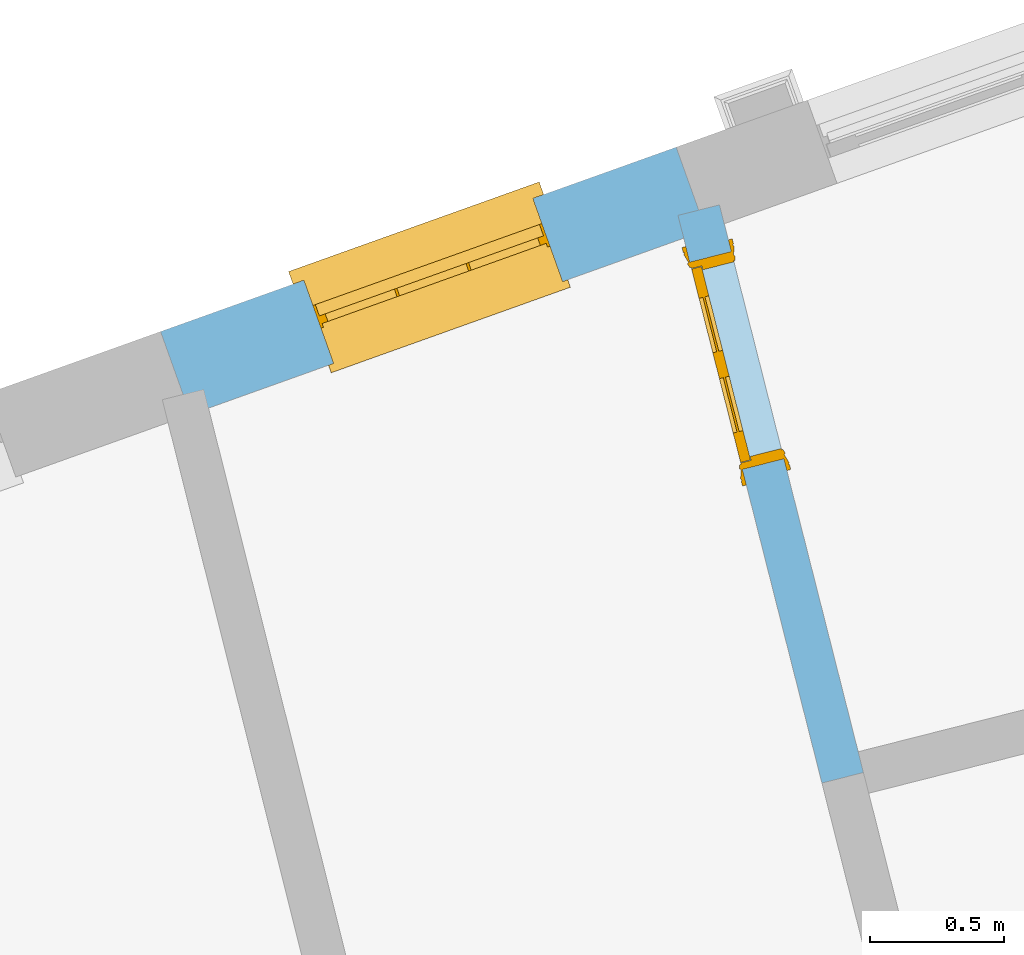
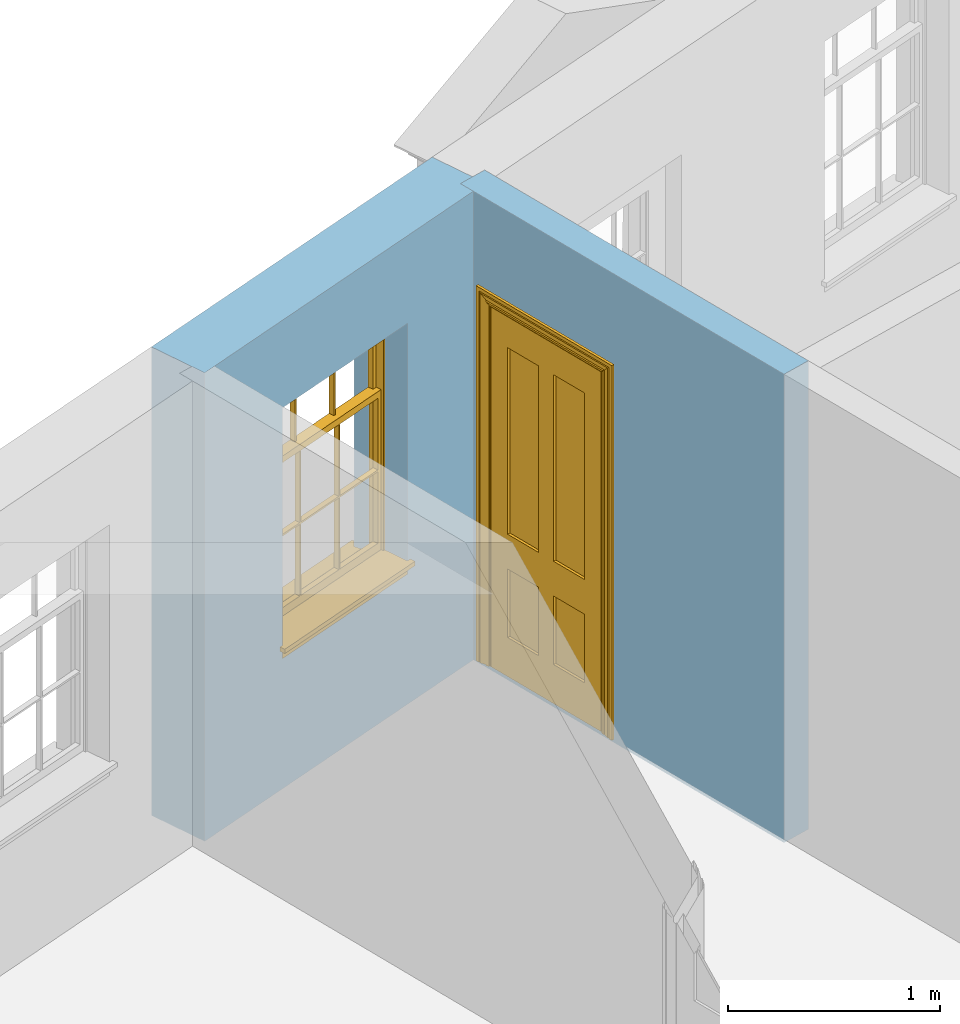
# One storey, part 10 of 15: 1 door, 1 window, 2 openings, plus 2 elements that do not belong to this part.
"""IFC2X3 building model written with IfcOpenShell, lengths in metres."""

from ifc_helpers import new_model, si_unit, frame, origin, place, context, subcontext, project, spatial, polyline, outline, extrude, faceted_brep, material, layer, layer_set, layer_usage, element, fill, save


model = new_model("IFC2X3")

# Units and contexts
model_context = context("Model", 3, world=origin())
body_context = subcontext(model_context, "Body", "Model", "MODEL_VIEW")
ifc_project = project(units=[si_unit("PLANEANGLEUNIT", "RADIAN"), si_unit("MASSUNIT", "GRAM", prefix="KILO"), si_unit("FORCEUNIT", "NEWTON", prefix="KILO"), si_unit("LENGTHUNIT", "METRE")], contexts=[model_context])

# Site, building, storey
site_placement = place(None, origin())
site = spatial("IfcSite", under=ifc_project, at=site_placement, CompositionType="ELEMENT")
building_placement = place(None, origin())
building = spatial("IfcBuilding", under=site, at=building_placement, Name="Building plot-13", CompositionType="ELEMENT")
storey_placement = place(None, frame((0.0, 0.0, 4.0)))
storey = spatial("IfcBuildingStorey", under=building, at=storey_placement, Name="Floor 0", CompositionType="ELEMENT", Elevation=4.0)

# Wall, opening, window
ifc_material_1 = material(Name="Masonry")
ifc_layer_1 = layer(ifc_material_1, 0.33, ventilated=False)
ifc_layer_set_1 = layer_set([ifc_layer_1], Name="My Wall")
ifc_layer_usage_1 = layer_usage(ifc_layer_set_1, "AXIS2", "NEGATIVE", 0.08)
wall_1_placement = place(storey_placement, origin())
wall_1 = element("IfcWallStandardCase", 1, at=wall_1_placement, inside=storey, material=ifc_layer_usage_1, Name="exterior", context=body_context, shape_type="SweptSolid", body=[
    extrude(outline(polyline([(72.090338058868, 49.7513205451126), (71.9792289491637, 50.0620531725284), (70.0510857180657, 49.3726042415572), (70.16219482777, 49.0618716141414), (72.090338058868, 49.7513205451126)])), origin(), (0.0, 0.0, 1.0), 2.7),
])
opening_1_placement = place(storey_placement, frame((0.0, 0.0, 0.75)))
opening_1 = element("IfcOpeningElement", 2, at=opening_1_placement, cuts=wall_1, Name="Opening", ObjectType="Opening", context=body_context, shape_type="SweptSolid", body=[
    extrude(outline(polyline([(71.4435917138395, 49.870524600726), (70.5867229533899, 49.5641328133596), (70.6978320630942, 49.2534001859438), (71.5547008235438, 49.5597919733102), (71.4435917138395, 49.870524600726)])), origin(), (0.0, 0.0, 1.0), 1.445),
])
window_placement = place(storey_placement, frame((71.5277652817973, 49.635121095108, 0.75), z_axis=(0.0, 0.0, 1.0), x_axis=(-0.856868760449586, -0.306391787366422, 0.0)))
window = element("IfcWindow", 3, at=window_placement, inside=storey, Name="circulation street window", OverallHeight=1.445, OverallWidth=0.91, context=body_context, shape_type="Brep", held_by="IfcProductRepresentation", body=[
    faceted_brep([(0.876875, -0.105, 0.999097), (0.876875, -0.105, 1.411875), (0.9, -0.105, 1.435), (0.033125, -0.105, 1.411875), (0.033125, -0.105, 0.999097), (0.01, -0.105, 1.435), (0.033125, -0.135, 1.411875), (0.01, -0.135, 1.435), (0.033125, -0.135, 0.999097), (0.876875, -0.135, 1.411875), (0.876875, -0.135, 0.999097), (0.9, -0.135, 1.435), (0.033125, -0.105, 0.960972), (0.01, -0.105, 0.960972), (0.033125, -0.105, 0.548195), (0.876875, -0.105, 0.960972), (0.876875, -0.105, 0.548195), (0.9, -0.105, 0.960972), (0.876875, -0.105, 0.538195), (0.876875, -0.105, 0.125417), (0.9, -0.105, 0.077167), (0.033125, -0.105, 0.125417), (0.033125, -0.105, 0.538195), (0.01, -0.105, 0.077167), (0.9, -0.135, 0.960972), (0.01, -0.135, 0.960972), (-0.0425, -0.25, 0.01), (-0.0425, -0.3, 0.001667), (0.0, -0.25, 0.01), (0.9525, -0.25, 0.01), (0.91, -0.25, 0.01), (0.9525, -0.3, 0.001667), (-0.02, 0.08, 0.077167), (0.0, 0.08, 0.077167), (-0.02, 0.11, 0.077167), (0.0, -0.06, 0.077167), (0.01, -0.06, 0.077167), (0.91, -0.06, 0.077167), (0.91, 0.08, 0.077167), (0.9, -0.06, 0.077167), (0.93, 0.08, 0.077167), (0.93, 0.11, 0.077167), (0.01, -0.105, 0.999097), (0.01, -0.075, 0.999097), (0.9, -0.105, 0.999097), (0.9, -0.075, 0.999097), (0.876875, -0.075, 0.125417), (0.876875, -0.075, 0.538195), (0.9, -0.075, 0.077167), (0.876875, -0.075, 0.548195), (0.876875, -0.075, 0.960972), (0.033125, -0.075, 0.125417), (0.01, -0.075, 0.077167), (0.033125, -0.075, 0.538195), (0.033125, -0.075, 0.960972), (0.033125, -0.075, 0.548195), (-0.02, 0.08, 0.052167), (-0.02, 0.11, 0.052167), (0.93, 0.11, 0.052167), (0.93, 0.08, 0.052167), (0.91, 0.08, 0.052167), (0.0, 0.08, 0.052167), (0.91, -0.15, 0.026667), (0.0, -0.15, 0.026667), (-0.0425, -0.3, -0.123333), (0.9525, -0.3, -0.123333), (-0.0425, -0.25, -0.123333), (0.9525, -0.25, -0.123333), (0.01, -0.06, 1.435), (0.9, -0.06, 1.435), (0.0, -0.06, 1.445), (0.91, -0.06, 1.445), (0.01, -0.15, 0.077167), (0.9, -0.15, 0.077167), (0.592292, -0.105, 0.125417), (0.592292, -0.075, 0.125417), (0.317708, -0.075, 0.125417), (0.317708, -0.105, 0.125417), (0.592292, -0.105, 0.548195), (0.317708, -0.105, 0.548195), (0.317708, -0.105, 0.538195), (0.592292, -0.105, 0.538195), (0.592292, -0.075, 0.548195), (0.317708, -0.075, 0.548195), (0.602292, -0.075, 0.548195), (0.602292, -0.105, 0.548195), (0.317708, -0.075, 0.538195), (0.307708, -0.075, 0.125417), (0.307708, -0.075, 0.538195), (0.602292, -0.075, 0.538195), (0.602292, -0.075, 0.125417), (0.592292, -0.075, 0.538195), (0.307708, -0.075, 0.548195), (0.317708, -0.075, 0.960972), (0.307708, -0.075, 0.960972), (0.602292, -0.075, 0.960972), (0.592292, -0.075, 0.960972), (0.307708, -0.105, 0.538195), (0.307708, -0.105, 0.125417), (0.307708, -0.105, 0.548195), (0.307708, -0.105, 0.960972), (0.592292, -0.105, 0.960972), (0.317708, -0.105, 0.960972), (0.602292, -0.105, 0.960972), (0.602292, -0.105, 0.538195), (0.602292, -0.105, 0.125417), (0.317708, -0.135, 1.411875), (0.307708, -0.135, 1.411875), (0.307708, -0.135, 0.999097), (0.317708, -0.135, 0.999097), (0.602292, -0.135, 1.411875), (0.592292, -0.135, 1.411875), (0.592292, -0.135, 0.999097), (0.602292, -0.135, 0.999097), (0.317708, -0.105, 0.999097), (0.307708, -0.105, 0.999097), (0.307708, -0.105, 1.411875), (0.317708, -0.105, 1.411875), (0.602292, -0.105, 0.999097), (0.592292, -0.105, 0.999097), (0.592292, -0.105, 1.411875), (0.602292, -0.105, 1.411875), (0.91, -0.15, 1.445), (0.9, -0.15, 1.435), (0.01, -0.15, 1.435), (0.0, -0.15, 1.445), (0.91, -0.25, 0.0), (0.0, -0.25, 0.0), (0.91, 0.08, 0.0), (0.0, 0.08, 0.0)], [[[0, 1, 2]], [[3, 4, 5]], [[6, 7, 8]], [[9, 10, 11]], [[12, 13, 14]], [[15, 16, 17]], [[18, 19, 20]], [[21, 22, 23]], [[24, 15, 17]], [[13, 12, 25]], [[26, 27, 28]], [[29, 30, 31]], [[32, 33, 34]], [[35, 36, 33]], [[37, 38, 39]], [[40, 41, 38]], [[42, 4, 43]], [[44, 45, 0]], [[46, 47, 48]], [[49, 50, 45]], [[51, 52, 53]], [[54, 55, 43]], [[38, 33, 36, 39]], [[41, 34, 33, 38]], [[56, 32, 34, 57]], [[57, 34, 41, 58]], [[58, 41, 40, 59]], [[57, 58, 60, 61]], [[52, 48, 39, 36]], [[62, 63, 28, 30]], [[27, 31, 30, 28]], [[27, 64, 65, 31]], [[66, 67, 65, 64]], [[2, 5, 68, 69]], [[68, 70, 71, 69]], [[20, 23, 72, 73]], [[73, 72, 63, 62]], [[74, 75, 76, 77]], [[78, 79, 80, 81]], [[78, 82, 83, 79]], [[16, 49, 84, 85]], [[86, 76, 87, 88]], [[89, 90, 75, 91]], [[92, 88, 53, 55]], [[82, 91, 86, 83]], [[93, 83, 92, 94]], [[95, 84, 82, 96]], [[89, 84, 49, 47]], [[97, 88, 87, 98]], [[22, 53, 88, 97]], [[81, 91, 75, 74]], [[80, 86, 91, 81]], [[77, 76, 86, 80]], [[99, 92, 55, 14]], [[100, 94, 92, 99]], [[101, 96, 82, 78]], [[79, 83, 93, 102]], [[85, 84, 95, 103]], [[104, 89, 47, 18]], [[105, 90, 89, 104]], [[104, 18, 16, 85]], [[80, 97, 98, 77]], [[104, 81, 74, 105]], [[103, 101, 78, 85]], [[99, 14, 22, 97]], [[102, 100, 99, 79]], [[106, 107, 108, 109]], [[110, 111, 112, 113]], [[114, 115, 116, 117]], [[118, 119, 120, 121]], [[107, 116, 115, 108]], [[111, 120, 119, 112]], [[109, 114, 117, 106]], [[113, 118, 121, 110]], [[85, 78, 81, 104]], [[84, 89, 91, 82]], [[83, 86, 88, 92]], [[79, 99, 97, 80]], [[109, 112, 119, 114]], [[102, 93, 96, 101]], [[106, 117, 120, 111]], [[98, 87, 51, 21]], [[6, 3, 116, 107]], [[110, 121, 1, 9]], [[19, 46, 90, 105]], [[26, 66, 64, 27]], [[29, 31, 65, 67]], [[25, 24, 112, 109]], [[11, 7, 106, 111]], [[75, 48, 52, 76]], [[43, 45, 96, 93]], [[45, 43, 114, 119]], [[5, 2, 120, 117]], [[24, 25, 102, 101]], [[42, 5, 4]], [[2, 44, 0]], [[49, 45, 48, 47]], [[52, 43, 55, 53]], [[14, 13, 23, 22]], [[20, 17, 16, 18]], [[24, 11, 10]], [[25, 8, 7]], [[8, 4, 3, 6]], [[9, 1, 0, 10]], [[15, 50, 49, 16]], [[18, 47, 46, 19]], [[21, 51, 53, 22]], [[14, 55, 54, 12]], [[44, 2, 69, 45]], [[68, 5, 42, 43]], [[36, 35, 70, 68]], [[39, 69, 71, 37]], [[62, 122, 123, 73]], [[63, 72, 124, 125]], [[8, 108, 115, 4]], [[113, 10, 0, 118]], [[94, 100, 12, 54]], [[17, 20, 73, 24]], [[72, 23, 13, 25]], [[52, 36, 68, 43]], [[69, 39, 48, 45]], [[11, 24, 73, 123]], [[7, 124, 72, 25]], [[23, 77, 98]], [[98, 21, 23]], [[105, 74, 20]], [[20, 19, 105]], [[20, 74, 77, 23]], [[113, 112, 24]], [[24, 10, 113]], [[25, 109, 108]], [[108, 8, 25]], [[110, 9, 11]], [[11, 111, 110]], [[7, 6, 107]], [[107, 106, 7]], [[5, 117, 116]], [[116, 3, 5]], [[121, 120, 2]], [[2, 1, 121]], [[11, 123, 124, 7]], [[122, 125, 124, 123]], [[43, 93, 94]], [[94, 54, 43]], [[96, 45, 95]], [[50, 95, 45]], [[15, 103, 95, 50]], [[48, 75, 90]], [[90, 46, 48]], [[87, 76, 52]], [[52, 51, 87]], [[103, 15, 24]], [[24, 101, 103]], [[100, 102, 25]], [[25, 12, 100]], [[115, 114, 43]], [[43, 4, 115]], [[118, 0, 45]], [[45, 119, 118]], [[71, 70, 125, 122]], [[70, 35, 63, 125]], [[122, 62, 37, 71]], [[126, 67, 66, 127]], [[60, 58, 59]], [[38, 60, 59, 40]], [[61, 56, 57]], [[32, 56, 61, 33]], [[61, 60, 128, 129]], [[62, 60, 38, 37]], [[126, 128, 60, 62]], [[33, 61, 63, 35]], [[61, 129, 127, 63]], [[128, 126, 127, 129]], [[28, 127, 66, 26]], [[63, 127, 28]], [[29, 67, 126, 30]], [[30, 126, 62]]]),
])
fill(opening_1, window)

# Wall, opening, door
ifc_material_2 = material(Name="Masonry")
ifc_layer_2 = layer(ifc_material_2, 0.16, ventilated=False)
ifc_layer_set_2 = layer_set([ifc_layer_2], Name="My Wall")
ifc_layer_usage_2 = layer_usage(ifc_layer_set_2, "AXIS2", "NEGATIVE", 0.08)
wall_2_placement = place(storey_placement, origin())
wall_2 = element("IfcWallStandardCase", 4, at=wall_2_placement, inside=storey, material=ifc_layer_usage_2, Name="interior", context=body_context, shape_type="SweptSolid", body=[
    extrude(outline(polyline([(72.5242252597805, 47.684308839971), (72.6793147976619, 47.7236437511786), (72.1409472860622, 49.8463171225142), (71.9858577481808, 49.8069822113066), (72.5242252597805, 47.684308839971)])), origin(), (0.0, 0.0, 1.0), 2.7),
])
opening_2_placement = place(storey_placement, frame((0.0, 0.0, 0.0199999999999996)))
opening_2 = element("IfcOpeningElement", 5, at=opening_2_placement, cuts=wall_2, Name="Opening", ObjectType="Opening", context=body_context, shape_type="SweptSolid", body=[
    extrude(outline(polyline([(72.3818736172093, 48.8963937029903), (72.1851990611709, 49.6718413923976), (72.0301095232894, 49.6325064811899), (72.2267840793278, 48.8570587917826), (72.3818736172093, 48.8963937029903)])), origin(), (0.0, 0.0, 1.0), 2.1),
])
door_placement = place(storey_placement, frame((72.3043288482685, 48.8767262473865, 0.0199999999999996), z_axis=(0.0, 0.0, 1.0), x_axis=(-0.196674556038388, 0.775447689407287, 0.0)))
door = element("IfcDoor", 6, at=door_placement, inside=storey, Name="circulation inside door", OverallHeight=2.1, OverallWidth=0.8, context=body_context, shape_type="Brep", held_by="IfcProductRepresentation", body=[
    faceted_brep([(0.773, 0.08, 1.895), (0.66, 0.08, 1.895), (0.66, 0.08, 2.073), (0.773, 0.08, 2.073), (0.773, 0.08, 0.82), (0.66, 0.08, 0.82), (0.45, 0.08, 1.895), (0.45, 0.08, 2.073), (0.773, 0.08, 0.62), (0.66, 0.08, 0.62), (0.66, 0.065, 0.82), (0.66, 0.065, 1.895), (0.45, 0.065, 1.895), (0.35, 0.08, 1.895), (0.35, 0.08, 2.073), (0.773, 0.08, 0.225), (0.66, 0.08, 0.225), (0.45, 0.08, 0.62), (0.45, 0.08, 0.82), (0.45, 0.065, 0.82), (0.35, 0.08, 0.82), (0.14, 0.08, 2.073), (0.14, 0.08, 1.895), (0.773, 0.08, 0.0), (0.66, 0.08, 0.0), (0.66, 0.065, 0.225), (0.66, 0.065, 0.62), (0.45, 0.065, 0.62), (0.35, 0.08, 0.62), (0.35, 0.065, 0.82), (0.35, 0.065, 1.895), (0.14, 0.065, 1.895), (0.027, 0.08, 2.073), (0.027, 0.08, 1.895), (0.773, 0.042, 0.0), (0.66, 0.042, 0.0), (0.45, 0.08, 0.0), (0.45, 0.08, 0.225), (0.45, 0.065, 0.225), (0.35, 0.08, 0.225), (0.14, 0.08, 0.82), (0.14, 0.08, 0.62), (0.14, 0.065, 0.82), (0.027, 0.08, 0.82), (0.773, 0.042, 0.225), (0.66, 0.042, 0.225), (0.45, 0.042, 0.0), (0.35, 0.08, 0.0), (0.35, 0.065, 0.225), (0.35, 0.065, 0.62), (0.14, 0.065, 0.62), (0.027, 0.08, 0.62), (0.773, 0.042, 0.62), (0.66, 0.042, 0.62), (0.45, 0.042, 0.225), (0.35, 0.042, 0.0), (0.14, 0.08, 0.225), (0.14, 0.08, 0.0), (0.14, 0.065, 0.225), (0.027, 0.08, 0.225), (0.773, 0.042, 0.82), (0.66, 0.042, 0.82), (0.66, 0.057, 0.62), (0.66, 0.057, 0.225), (0.45, 0.057, 0.225), (0.35, 0.042, 0.225), (0.14, 0.042, 0.0), (0.027, 0.08, 0.0), (0.773, 0.042, 1.895), (0.66, 0.042, 1.895), (0.45, 0.042, 0.62), (0.45, 0.042, 0.82), (0.45, 0.057, 0.62), (0.35, 0.042, 0.62), (0.14, 0.042, 0.225), (0.027, 0.042, 0.0), (0.773, 0.042, 2.073), (0.66, 0.042, 2.073), (0.66, 0.057, 1.895), (0.66, 0.057, 0.82), (0.45, 0.057, 0.82), (0.35, 0.042, 0.82), (0.35, 0.057, 0.62), (0.35, 0.057, 0.225), (0.14, 0.057, 0.225), (0.027, 0.042, 0.225), (0.45, 0.042, 1.895), (0.45, 0.042, 2.073), (0.45, 0.057, 1.895), (0.35, 0.042, 1.895), (0.14, 0.042, 0.82), (0.14, 0.042, 0.62), (0.14, 0.057, 0.62), (0.027, 0.042, 0.62), (0.35, 0.042, 2.073), (0.35, 0.057, 1.895), (0.35, 0.057, 0.82), (0.14, 0.057, 0.82), (0.027, 0.042, 0.82), (0.14, 0.042, 2.073), (0.14, 0.042, 1.895), (0.14, 0.057, 1.895), (0.027, 0.042, 1.895), (0.027, 0.042, 2.073), (0.02, 0.085, 0.0), (0.005, 0.09, 0.0), (0.005, 0.09, 2.095), (0.02, 0.085, 2.08), (0.02, 0.08, 0.0), (0.0, 0.085, 0.0), (0.0, 0.085, 2.1), (0.795, 0.09, 2.095), (0.78, 0.085, 2.08), (0.02, 0.08, 2.08), (0.0, 0.08, 0.0), (-0.032, 0.095, 0.0), (-0.032, 0.095, 2.132), (0.8, 0.085, 2.1), (0.795, 0.09, 0.0), (0.78, 0.085, 0.0), (0.78, 0.08, 2.08), (0.04, 0.04, 0.0), (0.025, 0.04, 0.0), (0.025, 0.04, 2.075), (0.04, 0.04, 2.06), (-0.04, 0.09, 0.0), (-0.04, 0.09, 2.14), (0.832, 0.095, 2.132), (0.8, 0.085, 0.0), (0.78, 0.08, 0.0), (0.8, 0.08, 0.0), (0.86, 0.08, 0.0), (0.86, 0.08, 2.16), (0.8, 0.08, 2.1), (-0.06, 0.08, 2.16), (0.0, 0.08, 2.1), (-0.06, 0.08, 0.0), (-0.04, 0.095, 0.0), (-0.04, 0.095, 2.14), (0.84, 0.09, 2.14), (0.832, 0.095, 0.0), (0.84, 0.09, 0.0), (0.86, 0.095, 0.0), (0.86, 0.095, 2.16), (-0.06, 0.095, 2.16), (-0.06, 0.095, 0.0), (0.84, 0.095, 0.0), (0.84, 0.095, 2.14), (-0.025, -0.095, 0.0), (-0.025, -0.09, 0.0), (-0.025, -0.09, 2.125), (-0.025, -0.095, 2.125), (-0.017, -0.095, 0.0), (-0.017, -0.095, 2.117), (0.825, -0.09, 2.125), (0.825, -0.095, 2.125), (0.825, -0.095, 0.0), (0.845, -0.095, 0.0), (-0.045, -0.095, 2.145), (-0.045, -0.095, 0.0), (0.845, -0.095, 2.145), (0.015, -0.085, 0.0), (0.015, -0.085, 2.085), (0.817, -0.095, 2.117), (0.825, -0.09, 0.0), (0.845, -0.08, 0.0), (0.845, -0.08, 2.145), (-0.045, -0.08, 2.145), (-0.045, -0.08, 0.0), (0.02, -0.09, 0.0), (0.02, -0.09, 2.08), (0.785, -0.085, 2.085), (0.817, -0.095, 0.0), (0.8, -0.08, 0.0), (0.8, -0.08, 2.1), (0.0, -0.08, 2.1), (0.0, -0.08, 0.0), (0.035, -0.085, 0.0), (0.035, -0.085, 2.065), (0.78, -0.09, 2.08), (0.785, -0.085, 0.0), (0.775, 0.04, 2.075), (0.76, 0.04, 2.06), (0.035, -0.08, 2.065), (0.035, -0.08, 0.0), (0.765, -0.085, 2.065), (0.78, -0.09, 0.0), (0.765, -0.08, 0.0), (0.765, -0.08, 2.065), (0.765, -0.085, 0.0), (0.04, -0.08, 2.06), (0.04, -0.08, 0.0), (0.76, -0.08, 2.06), (0.76, -0.08, 0.0), (0.76, 0.04, 0.0), (0.775, 0.04, 0.0), (0.025, 0.08, 0.0), (0.025, 0.08, 2.075), (0.775, 0.08, 0.0), (0.775, 0.08, 2.075)], [[[0, 1, 2, 3]], [[1, 0, 4, 5]], [[1, 6, 7, 2]], [[8, 9, 5, 4]], [[1, 5, 10, 11]], [[6, 1, 11, 12]], [[6, 13, 14, 7]], [[15, 16, 9, 8]], [[9, 17, 18, 5]], [[5, 18, 19, 10]], [[10, 19, 12, 11]], [[18, 6, 12, 19]], [[18, 20, 13, 6]], [[21, 14, 13, 22]], [[23, 24, 16, 15]], [[9, 16, 25, 26]], [[17, 9, 26, 27]], [[17, 28, 20, 18]], [[13, 20, 29, 30]], [[22, 13, 30, 31]], [[32, 21, 22, 33]], [[34, 35, 24, 23]], [[24, 36, 37, 16]], [[16, 37, 38, 25]], [[25, 38, 27, 26]], [[37, 17, 27, 38]], [[37, 39, 28, 17]], [[40, 20, 28, 41]], [[20, 40, 42, 29]], [[31, 30, 29, 42]], [[40, 22, 31, 42]], [[33, 22, 40, 43]], [[35, 34, 44, 45]], [[35, 46, 36, 24]], [[36, 47, 39, 37]], [[28, 39, 48, 49]], [[41, 28, 49, 50]], [[43, 40, 41, 51]], [[45, 44, 52, 53]], [[46, 35, 45, 54]], [[46, 55, 47, 36]], [[56, 39, 47, 57]], [[39, 56, 58, 48]], [[50, 49, 48, 58]], [[56, 41, 50, 58]], [[51, 41, 56, 59]], [[53, 52, 60, 61]], [[45, 53, 62, 63]], [[54, 45, 63, 64]], [[55, 46, 54, 65]], [[55, 66, 57, 47]], [[59, 56, 57, 67]], [[61, 60, 68, 69]], [[70, 53, 61, 71]], [[53, 70, 72, 62]], [[72, 64, 63, 62]], [[70, 54, 64, 72]], [[65, 54, 70, 73]], [[65, 74, 66, 55]], [[67, 57, 66, 75]], [[69, 68, 76, 77]], [[61, 69, 78, 79]], [[71, 61, 79, 80]], [[73, 70, 71, 81]], [[65, 73, 82, 83]], [[74, 65, 83, 84]], [[74, 85, 75, 66]], [[86, 69, 77, 87]], [[69, 86, 88, 78]], [[88, 80, 79, 78]], [[86, 71, 80, 88]], [[81, 71, 86, 89]], [[73, 81, 90, 91]], [[73, 91, 92, 82]], [[83, 82, 92, 84]], [[91, 74, 84, 92]], [[91, 93, 85, 74]], [[89, 86, 87, 94]], [[81, 89, 95, 96]], [[90, 81, 96, 97]], [[90, 98, 93, 91]], [[94, 99, 100, 89]], [[89, 100, 101, 95]], [[101, 97, 96, 95]], [[100, 90, 97, 101]], [[100, 102, 98, 90]], [[99, 103, 102, 100]], [[32, 103, 99, 21]], [[102, 103, 32, 33]], [[98, 102, 33, 43]], [[21, 99, 94, 14]], [[94, 87, 7, 14]], [[7, 87, 77, 2]], [[76, 3, 2, 77]], [[43, 51, 93, 98]], [[51, 59, 85, 93]], [[67, 75, 85, 59]], [[34, 23, 15, 44]], [[44, 15, 8, 52]], [[52, 8, 4, 60]], [[0, 68, 60, 4]], [[0, 3, 76, 68]], [[104, 105, 106, 107]], [[104, 108, 109, 105]], [[105, 109, 110, 106]], [[107, 106, 111, 112]], [[107, 113, 108, 104]], [[114, 109, 108]], [[109, 115, 116, 110]], [[106, 110, 117, 111]], [[112, 111, 118, 119]], [[113, 107, 112, 120]], [[121, 122, 123, 124]], [[115, 109, 114, 125]], [[115, 125, 126, 116]], [[110, 116, 127, 117]], [[111, 117, 128, 118]], [[118, 128, 129, 119]], [[120, 112, 119, 129]], [[130, 129, 128]], [[130, 131, 132, 133]], [[133, 132, 134, 135]], [[135, 134, 136, 114]], [[136, 125, 114]], [[125, 137, 138, 126]], [[116, 126, 139, 127]], [[117, 127, 140, 128]], [[141, 130, 128, 140]], [[131, 130, 141]], [[131, 142, 143, 132]], [[132, 143, 144, 134]], [[134, 144, 145, 136]], [[137, 125, 136, 145]], [[143, 142, 146]], [[143, 146, 147]], [[137, 145, 144]], [[143, 147, 138]], [[138, 137, 144]], [[143, 138, 144]], [[126, 138, 147, 139]], [[127, 139, 141, 140]], [[142, 131, 141, 146]], [[139, 147, 146, 141]], [[148, 149, 150, 151]], [[149, 152, 153, 150]], [[151, 150, 154, 155]], [[155, 156, 157]], [[158, 159, 148]], [[158, 148, 151]], [[155, 157, 160]], [[158, 151, 155]], [[155, 160, 158]], [[152, 161, 162, 153]], [[150, 153, 163, 154]], [[155, 154, 164, 156]], [[156, 164, 165, 157]], [[157, 165, 166, 160]], [[160, 166, 167, 158]], [[158, 167, 168, 159]], [[161, 169, 170, 162]], [[153, 162, 171, 163]], [[154, 163, 172, 164]], [[165, 164, 173]], [[165, 173, 174, 166]], [[166, 174, 175, 167]], [[167, 175, 176, 168]], [[169, 177, 178, 170]], [[162, 170, 179, 171]], [[163, 171, 180, 172]], [[172, 180, 173, 164]], [[124, 123, 181, 182]], [[183, 178, 177, 184]], [[170, 178, 185, 179]], [[171, 179, 186, 180]], [[187, 173, 180]], [[185, 188, 187, 189]], [[188, 185, 178, 183]], [[179, 185, 189, 186]], [[189, 187, 180, 186]], [[190, 183, 184, 191]], [[192, 188, 183, 190]], [[191, 184, 122, 121]], [[124, 190, 191, 121]], [[193, 187, 188, 192]], [[182, 192, 190, 124]], [[184, 176, 122]], [[194, 195, 187, 193]], [[192, 182, 194, 193]], [[161, 176, 184]], [[114, 108, 122, 176]], [[173, 187, 195]], [[152, 149, 176, 161]], [[169, 161, 184, 177]], [[196, 122, 108]], [[176, 175, 135, 114]], [[173, 195, 129, 130]], [[176, 149, 168]], [[123, 122, 196, 197]], [[196, 108, 113, 197]], [[175, 174, 133, 135]], [[198, 129, 195]], [[133, 174, 173, 130]], [[159, 168, 149, 148]], [[181, 123, 197, 199]], [[197, 113, 120, 199]], [[199, 120, 129, 198]], [[195, 181, 199, 198]], [[195, 194, 182, 181]]]),
])
fill(opening_2, door)

save(model, "model.ifc")
